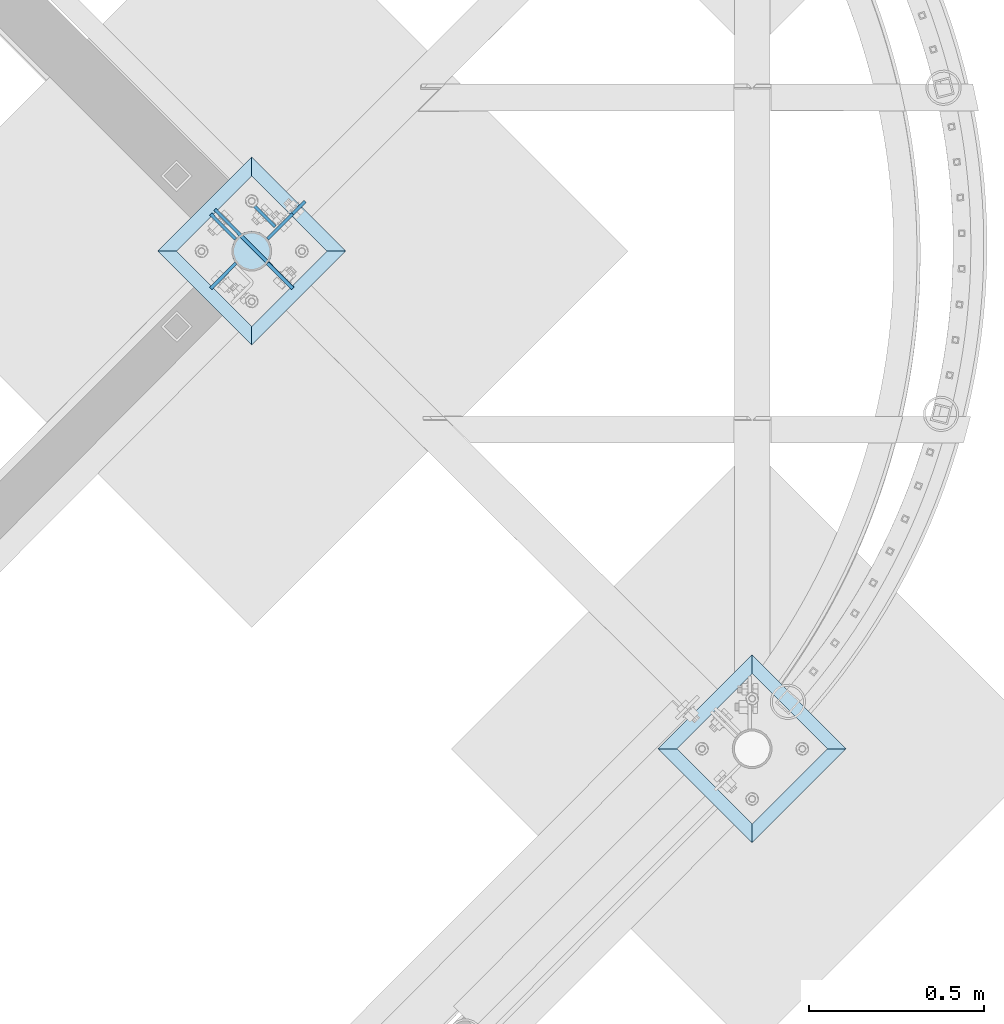
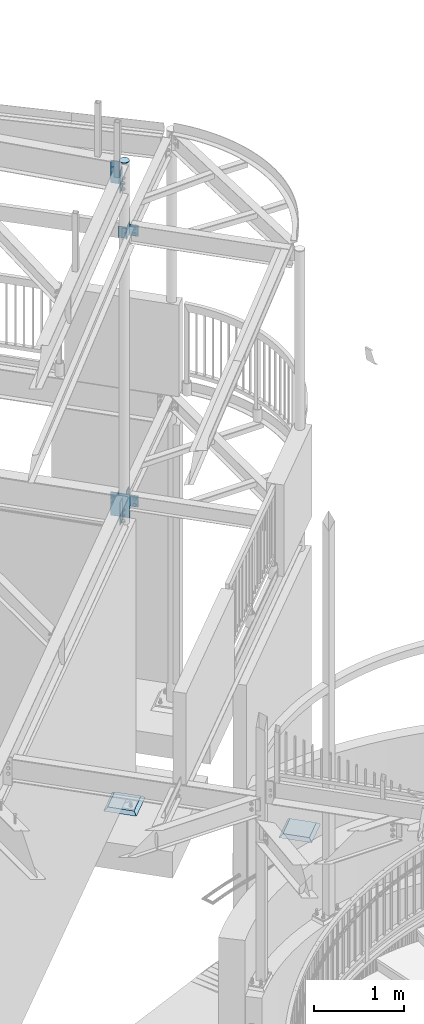
# One storey, part 921 of 975: 11 plates.
"""IFC2X3 building model written with IfcOpenShell, lengths in millimetres."""

import ifcopenshell
import ifcopenshell.guid

model = None  # the IFC model being written
_history = None  # IfcOwnerHistory: only IFC2X3 demands one
_inside = {}  # id of a spatial element -> (the spatial element, [elements in it])
_under = {}  # id of a project, library or spatial element -> (it, [spatial elements below it])
_declared = {}  # id of a project -> (the project, [libraries it declares])
_typed = {}  # id of a type object -> (the type object, [elements of that type])
_made_of = {}  # id of a material, layer set ... -> (it, [elements and type objects made of it])


def new_model(schema):
    """Start an empty IFC model of exactly this schema.

    Asked for "IFC4X3", IfcOpenShell would pick the latest addendum, in which some entities
    have other attributes; the version numbers below select the first issue.
    IFC2X3 requires an IfcOwnerHistory on every rooted entity: one is made here for all.
    """
    global model, _history
    if schema == "IFC4X3":
        model = ifcopenshell.file(schema_version=(4, 3, 0, 0))
    else:
        model = ifcopenshell.file(schema=schema)
    _inside.clear()
    _under.clear()
    _declared.clear()
    _typed.clear()
    _made_of.clear()
    _history = None
    if model.schema == "IFC2X3":
        org = make("IfcOrganization", Name="unknown")
        user = make(
            "IfcPersonAndOrganization",
            ThePerson=make("IfcPerson", FamilyName="unknown"),
            TheOrganization=org,
        )
        app = make(
            "IfcApplication",
            ApplicationDeveloper=org,
            Version="unknown",
            ApplicationFullName="unknown",
            ApplicationIdentifier="unknown",
        )
        _history = make(
            "IfcOwnerHistory",
            OwningUser=user,
            OwningApplication=app,
            ChangeAction="ADDED",
            CreationDate=0,
        )
    return model


def make(cls, **values):
    """One entity of the class cls with the attributes given. An attribute that is None is left unset."""
    return model.create_entity(
        cls, **{name: value for name, value in values.items() if value is not None}
    )


def rooted(cls, **values):
    """An entity with a GlobalId (a new one), such as an element, a storey or a relation."""
    return make(cls, GlobalId=ifcopenshell.guid.new(), OwnerHistory=_history, **values)


def si_unit(unit_type, name, prefix=None):
    """IfcSIUnit, for example si_unit("LENGTHUNIT", "METRE", prefix="MILLI")."""
    return make("IfcSIUnit", UnitType=unit_type, Prefix=prefix, Name=name)


def assignment(units):
    """IfcUnitAssignment: the units of a project."""
    return None if units is None else make("IfcUnitAssignment", Units=units)


def point(xyz):
    """IfcCartesianPoint."""
    return None if xyz is None else make("IfcCartesianPoint", Coordinates=xyz)


def direction(xyz):
    """IfcDirection."""
    return None if xyz is None else make("IfcDirection", DirectionRatios=xyz)


def frame(location, z_axis=None, x_axis=None):
    """IfcAxis2Placement3D, a coordinate frame: its origin and axes. An axis left out is left unset."""
    return make(
        "IfcAxis2Placement3D",
        Location=point(location),
        Axis=direction(z_axis),
        RefDirection=direction(x_axis),
    )


def origin_with_axes():
    """The frame at (0, 0, 0) with the z axis (0, 0, 1) and the x axis (1, 0, 0) written out."""
    return frame((0.0, 0.0, 0.0), z_axis=(0.0, 0.0, 1.0), x_axis=(1.0, 0.0, 0.0))


def place(relative_to, where):
    """IfcLocalPlacement: puts the frame where relative to a parent placement (None: the world)."""
    return make(
        "IfcLocalPlacement", PlacementRelTo=relative_to, RelativePlacement=where
    )


def context(
    kind, dimensions, precision=None, world=None, true_north=None, identifier=None
):
    """IfcGeometricRepresentationContext, for example the 3D "Model" context."""
    return make(
        "IfcGeometricRepresentationContext",
        ContextIdentifier=identifier,
        ContextType=kind,
        CoordinateSpaceDimension=dimensions,
        Precision=precision,
        WorldCoordinateSystem=world,
        TrueNorth=true_north,
    )


def subcontext(parent, identifier, kind, view, scale=None):
    """IfcGeometricRepresentationSubContext, for example "Body" below "Model"."""
    return make(
        "IfcGeometricRepresentationSubContext",
        ContextIdentifier=identifier,
        ContextType=kind,
        ParentContext=parent,
        TargetScale=scale,
        TargetView=view,
    )


def project(units=None, contexts=None):
    """IfcProject with its units and contexts."""
    return rooted(
        "IfcProject",
        Name="project",
        RepresentationContexts=contexts,
        UnitsInContext=assignment(units),
    )


def spatial(cls, under=None, at=None, **own):
    """A site, building, storey or space (cls), placed at a placement, below another one or the project."""
    s = rooted(cls, ObjectPlacement=at, **own)
    if under is not None:
        _under.setdefault(under.id(), (under, []))[1].append(s)
    return s


def faces_of(points, faces, orient=None, outer=None):
    """IfcFace entities. A face is a list of loops; a loop is a list of indices into points, from 0.

    orient and outer hold one flag for each loop. By default every Orientation is true, the
    first loop of a face is its IfcFaceOuterBound and the others are IfcFaceBound.
    """
    made = []
    for i, loops in enumerate(faces):
        bounds = []
        for j, loop in enumerate(loops):
            is_outer = j == 0 if outer is None else outer[i][j]
            bounds.append(
                make(
                    "IfcFaceOuterBound" if is_outer else "IfcFaceBound",
                    Bound=make("IfcPolyLoop", Polygon=[points[k] for k in loop]),
                    Orientation=True if orient is None else orient[i][j],
                )
            )
        made.append(make("IfcFace", Bounds=bounds))
    return made


def faceted_brep(points, faces, orient=None, outer=None, voids=None):
    """IfcFacetedBrep: a solid bounded by flat faces; with voids (closed shells), ...WithVoids."""
    shared = [point(p) for p in points]
    hull = make("IfcClosedShell", CfsFaces=faces_of(shared, faces, orient, outer))
    if voids is None:
        return make("IfcFacetedBrep", Outer=hull)
    return make(
        "IfcFacetedBrepWithVoids",
        Outer=hull,
        Voids=[
            make(cls, CfsFaces=faces_of(shared, fs, o, b)) for cls, fs, o, b in voids
        ],
    )


def shape(context_of_items, identifier, shape_type, items):
    """IfcShapeRepresentation: the items that make up one representation, for example the "Body"."""
    return make(
        "IfcShapeRepresentation",
        ContextOfItems=context_of_items,
        RepresentationIdentifier=identifier,
        RepresentationType=shape_type,
        Items=items,
    )


def material(Name=None, Category=None):
    """IfcMaterial."""
    return make("IfcMaterial", Name=Name, Category=Category)


def made_of(thing, what):
    """Note that an element or type object is made of a material, layer set ...; save() writes the relation."""
    if what is not None:
        _made_of.setdefault(what.id(), (what, []))[1].append(thing)
    return thing


def type_object(cls, material=None, **own):
    """A type object (cls), such as IfcWallType, which elements share."""
    return made_of(rooted(cls, **own), material)


def element(
    cls,
    number,
    at=None,
    inside=None,
    cuts=None,
    type_object=None,
    material=None,
    context=None,
    identifier="Body",
    shape_type=None,
    held_by="IfcProductDefinitionShape",
    body=None,
    shapes=None,
    **own,
):
    """One element of the class cls, such as IfcWall. Its Tag is "e" and its number.

    at: its placement. inside: the storey or other place that contains it. cuts: it is an
    opening in that element (IfcRelVoidsElement). A single representation is given by context,
    identifier, shape_type and body (its items); several are given by shapes. held_by: the class
    of the entity that holds the representations. save() writes the other relations.
    """
    e = rooted(cls, Tag="e%d" % number, ObjectPlacement=at, **own)
    if body is not None:
        shapes = [shape(context, identifier, shape_type, body)]
    if shapes is not None:
        e.Representation = make(held_by, Representations=shapes)
    if inside is not None:
        _inside.setdefault(inside.id(), (inside, []))[1].append(e)
    if cuts is not None:
        rooted(
            "IfcRelVoidsElement", RelatingBuildingElement=cuts, RelatedOpeningElement=e
        )
    if type_object is not None:
        _typed.setdefault(type_object.id(), (type_object, []))[1].append(e)
    return made_of(e, material)


def aggregate(whole, parts):
    """IfcRelAggregates: a whole, such as a stair, and the parts it consists of."""
    return rooted("IfcRelAggregates", RelatingObject=whole, RelatedObjects=parts)


def save(model, path):
    """Write the relations noted so far, then the file.

    IfcRelAggregates (storeys below a building ...), IfcRelContainedInSpatialStructure (elements
    in a storey), IfcRelDefinesByType, IfcRelAssociatesMaterial and IfcRelDeclares: one each for
    every whole, place, type object, material and project.
    """
    for whole, parts in _under.values():
        aggregate(whole, parts)
    for where, things in _inside.values():
        rooted(
            "IfcRelContainedInSpatialStructure",
            RelatedElements=things,
            RelatingStructure=where,
        )
    for kind, things in _typed.values():
        rooted("IfcRelDefinesByType", RelatedObjects=things, RelatingType=kind)
    for what, things in _made_of.values():
        rooted("IfcRelAssociatesMaterial", RelatedObjects=things, RelatingMaterial=what)
    for by, libraries in _declared.values():
        rooted("IfcRelDeclares", RelatingContext=by, RelatedDefinitions=libraries)
    model.write(path)


model = new_model("IFC2X3")

# Units and contexts
model_context = context("Model", 3, precision=1e-05, world=origin_with_axes())
body_context = subcontext(model_context, "Body", "Model", "MODEL_VIEW")
ifc_project = project(units=[si_unit("LENGTHUNIT", "METRE", prefix="MILLI"), si_unit("AREAUNIT", "SQUARE_METRE"), si_unit("VOLUMEUNIT", "CUBIC_METRE"), si_unit("MASSUNIT", "GRAM", prefix="KILO"), si_unit("TIMEUNIT", "SECOND"), si_unit("PLANEANGLEUNIT", "RADIAN"), si_unit("SOLIDANGLEUNIT", "STERADIAN"), si_unit("THERMODYNAMICTEMPERATUREUNIT", "DEGREE_CELSIUS"), si_unit("LUMINOUSINTENSITYUNIT", "LUMEN")], contexts=[model_context])

# Site, building, storey
site_placement = place(None, origin_with_axes())
site = spatial("IfcSite", under=ifc_project, at=site_placement, CompositionType="ELEMENT")
building_placement = place(site_placement, origin_with_axes())
building = spatial("IfcBuilding", under=site, at=building_placement, Name="Undefined", CompositionType="ELEMENT")
storey_placement = place(building_placement, origin_with_axes())
storey = spatial("IfcBuildingStorey", under=building, at=storey_placement, Name="Undefined", CompositionType="ELEMENT", Elevation=0.0)

# Plates
ifc_material_1 = material(Name="STEEL/A36")
plate_type_1 = type_object("IfcPlateType", PredefinedType="NOTDEFINED")
for number, where, z_axis, x_axis, name in (
    (1, (34058.6898757685, 11631.937809576, 8417.04274375628), (-0.704876777842618, -0.709329773841623, 9.89945510809774e-09), (0.0, 0.0, -1.0), "PLATE"),
    (2, (34058.600015857, 11700.9897502071, 8436.38583040211), (-0.706980057333141, 0.70723348233326, 0.0), (0.0, 0.0, -1.0), "PLATE"),
):
    element("IfcPlate", number, at=place(storey_placement, frame(where, z_axis=z_axis, x_axis=x_axis)), inside=storey, type_object=plate_type_1, material=ifc_material_1, Name=name, context=body_context, shape_type="Brep", body=[
        faceted_brep([(0.0, -4.76250000000073, 0.0), (3.09228198602796e-11, -4.76250000006621, 101.59999847407), (3.09228198602796e-11, 4.7624999999407, 101.599998474074), (0.0, 4.76250000000073, 0.0), (304.799987792969, -4.76250000006621, 101.59999847407), (304.799987792969, 4.7624999999407, 101.599998474074), (304.799987792969, -4.76249999999982, 0.0), (304.799987792969, 4.76249999999982, 0.0)], [[[0, 1, 2, 3]], [[1, 4, 5, 2]], [[4, 6, 7, 5]], [[6, 0, 3, 7]], [[5, 7, 3, 2]], [[6, 4, 1, 0]]]),
    ])
for number, where, z_axis, x_axis, name in (
    (3, (34149.542759726, 11631.5828184462, 7594.59999999992), (0.709067143694186, -0.705140968695883, 0.0), (0.0, 0.0, -1.0), "PLATE"),
    (4, (34149.4921648451, 11701.5751692706, 3911.6), (0.707890224195014, 0.706322469194583, 0.0), (0.0, 0.0, -1.0), "PLATE"),
):
    element("IfcPlate", number, at=place(storey_placement, frame(where, z_axis=z_axis, x_axis=x_axis)), inside=storey, type_object=plate_type_1, material=ifc_material_1, Name=name, context=body_context, shape_type="Brep", body=[
        faceted_brep([(0.0, -4.76250000000073, 0.0), (0.0, -4.76249999983702, 101.970382690557), (0.0, 4.76250000017899, 101.970382690564), (0.0, 4.76250000000073, 0.0), (152.399993896484, -4.76249999983702, 101.970382690557), (152.399993896484, 4.76250000017899, 101.970382690564), (152.399993896484, -4.76250000000073, 0.0), (152.399993896484, 4.76250000000073, 0.0)], [[[0, 1, 2, 3]], [[1, 4, 5, 2]], [[4, 6, 7, 5]], [[6, 0, 3, 7]], [[5, 7, 3, 2]], [[6, 4, 1, 0]]]),
    ])
plate_1_placement = place(storey_placement, frame((34058.6755413739, 11631.9613130407, 3898.9), z_axis=(-0.705211376647204, -0.708997118645312, 0.0), x_axis=(0.0, 0.0, -1.0)))
element("IfcPlate", 5, at=plate_1_placement, inside=storey, type_object=plate_type_1, material=ifc_material_1, Name="PLATE", context=body_context, shape_type="Brep", body=[
    faceted_brep([(0.0, -4.76250000000073, 0.0), (0.0, -4.76250000004256, 102.063125610362), (0.0, 4.7624999999407, 102.063125610377), (0.0, 4.76250000000073, 0.0), (304.799987792969, -4.76250000004256, 102.063125610362), (304.799987792969, 4.7624999999407, 102.063125610377), (304.799987792969, -4.76249999999982, 0.0), (304.799987792969, 4.76249999999982, 0.0)], [[[0, 1, 2, 3]], [[1, 4, 5, 2]], [[4, 6, 7, 5]], [[6, 0, 3, 7]], [[5, 7, 3, 2]], [[6, 4, 1, 0]]]),
])
plate_type_2 = type_object("IfcPlateType", PredefinedType="NOTDEFINED")
plate_2_placement = place(storey_placement, frame((34149.4901762041, 11701.5784056277, 7493.0), z_axis=(0.707846168211467, 0.706366620211023, 0.0), x_axis=(0.0, 0.0, -1.0)))
element("IfcPlate", 6, at=plate_2_placement, inside=storey, type_object=plate_type_2, material=ifc_material_1, Name="PLATE", context=body_context, shape_type="Brep", body=[
    faceted_brep([(0.0, -4.76250000000073, 0.0), (0.0, -4.76249999995889, 152.774597167747), (0.0, 4.76250000002983, 152.774597167772), (0.0, 4.76250000000073, 0.0), (152.399993896484, -4.76249999995889, 152.774597167747), (152.399993896484, 4.76250000002983, 152.774597167772), (152.399993896484, -4.76250000000073, 0.0), (152.399993896484, 4.76250000000073, 0.0)], [[[0, 1, 2, 3]], [[1, 4, 5, 2]], [[4, 6, 7, 5]], [[6, 0, 3, 7]], [[5, 7, 3, 2]], [[6, 4, 1, 0]]]),
])
plate_type_3 = type_object("IfcPlateType", PredefinedType="NOTDEFINED")
plate_3_placement = place(storey_placement, frame((34171.1218852476, 11736.627046443, 7479.65399706807), z_axis=(-0.706980057333141, 0.70723348233326, 0.0), x_axis=(0.0, 0.0, -1.0)))
element("IfcPlate", 7, at=plate_3_placement, inside=storey, type_object=plate_type_3, material=ifc_material_1, Name="PLATE", context=body_context, shape_type="Brep", body=[
    faceted_brep([(0.0, -4.76250000000073, 0.0), (0.0, -4.76249999999982, 88.9000015258789), (0.0, 4.76249999999982, 88.9000015258789), (0.0, 4.76250000000073, 0.0), (152.399993896484, -4.76249999999982, 88.9000015258789), (152.399993896484, 4.76249999999982, 88.9000015258789), (152.399993896484, -4.76250000000073, 0.0), (152.399993896484, 4.76250000000073, 0.0)], [[[0, 1, 2, 3]], [[1, 4, 5, 2]], [[4, 6, 7, 5]], [[6, 0, 3, 7]], [[5, 7, 3, 2]], [[6, 4, 1, 0]]]),
])
plate_type_4 = type_object("IfcPlateType", PredefinedType="NOTDEFINED")
plate_4_placement = place(storey_placement, frame((34023.4401949106, 11666.5375000001, 8453.43750012522), z_axis=(0.707106781186513, -0.707106781186582, 3.1377567211166e-14), x_axis=(0.707106781186548, 0.707106781186548, 0.0)))
element("IfcPlate", 8, at=plate_4_placement, inside=storey, type_object=plate_type_4, material=ifc_material_1, Name="PLATE", context=body_context, shape_type="Brep", body=[
    faceted_brep([(-1.45519152283669e-10, -4.76250000000073, 57.1500015256606), (4.35028483294354, -4.76250000000073, 79.0203602693728), (4.35028483294354, 4.76250000000073, 79.0203602693728), (-1.45519152283669e-10, 4.76250000000073, 57.1500015256606), (16.7388479019119, -4.76250000000073, 97.5611551495967), (16.7388479019119, 4.76250000000073, 97.5611551495967), (35.2796427821067, -4.76250000000073, 109.949718218613), (35.2796427821067, 4.76250000000073, 109.949718218613), (57.1500015258789, -4.76250000000073, 114.300003051758), (57.1500015258789, 4.76250000000073, 114.300003051758), (79.0203602694728, -4.76250000000073, 109.949718218628), (79.0203602694728, 4.76250000000073, 109.949718218628), (97.5611551496495, -4.76250000000073, 97.5611551496477), (97.5611551496495, 4.76250000000073, 97.5611551496477), (109.949718218627, -4.76250000000073, 79.020360269471), (109.949718218627, 4.76250000000073, 79.020360269471), (114.300003051758, -4.76250000000073, 57.1500015258061), (114.300003051758, 4.76250000000073, 57.1500015258061), (109.949718218621, -4.76250000000073, 35.2796427821959), (109.949718218621, 4.76250000000073, 35.2796427821959), (97.5611551496231, -4.76250000000073, 16.7388479020083), (97.5611551496231, 4.76250000000073, 16.7388479020083), (79.020360269421, -4.76250000000073, 4.3502848330354), (79.020360269421, 4.76250000000073, 4.3502848330354), (57.1500015256597, -4.76250000000073, -7.27595761418343e-11), (57.1500015256597, 4.76250000000073, -7.27595761418343e-11), (35.2796427821222, -4.76250000000073, 4.35028483306451), (35.2796427821222, 4.76250000000073, 4.35028483306451), (16.7388479019883, -4.76250000000073, 16.7388479020083), (16.7388479019883, 4.76250000000073, 16.7388479020083), (4.35028483301994, -4.76250000000073, 35.2796427821268), (4.35028483301994, 4.76250000000073, 35.2796427821268)], [[[0, 1, 2, 3]], [[1, 4, 5, 2]], [[4, 6, 7, 5]], [[6, 8, 9, 7]], [[8, 10, 11, 9]], [[10, 12, 13, 11]], [[12, 14, 15, 13]], [[14, 16, 17, 15]], [[16, 18, 19, 17]], [[18, 20, 21, 19]], [[20, 22, 23, 21]], [[22, 24, 25, 23]], [[24, 26, 27, 25]], [[26, 28, 29, 27]], [[28, 30, 31, 29]], [[30, 0, 3, 31]], [[5, 7, 9, 11, 13, 15, 17, 19, 21, 23, 25, 27, 29, 31, 3, 2]], [[30, 28, 26, 24, 22, 20, 18, 16, 14, 12, 10, 8, 6, 4, 1, 0]]]),
])
plate_type_5 = type_object("IfcPlateType", PredefinedType="NOTDEFINED")
plate_5_placement = place(storey_placement, frame((34071.179113864, 11713.3266625662, 3911.60000000004), z_axis=(0.0, 0.0, -1.0), x_axis=(0.705007777009209, -0.709199573009272, 0.0)))
element("IfcPlate", 9, at=plate_5_placement, inside=storey, type_object=plate_type_5, material=ifc_material_1, Name="PLATE", context=body_context, shape_type="Brep", body=[
    faceted_brep([(0.0, -4.76250000000073, 0.0), (-102.469268798992, -4.7624999999025, 0.0), (-102.469268798985, 4.76250000008804, 0.0), (0.0, 4.76250000000073, 0.0), (-102.469268798992, -4.7624999999025, 317.5), (-102.469268798985, 4.76250000008804, 317.5), (119.39334106463, -4.76250000009168, 317.5), (119.393341064639, 4.76249999989886, 317.5), (119.39334106463, -4.76250000009168, 158.749993801117), (119.393341064639, 4.76249999989886, 158.749993801117), (119.876706025925, -4.76250000009532, 156.319954042094), (119.876706025934, 4.7624999999025, 156.319954042094), (121.253212976169, -4.76250000009895, 154.259865808017), (121.253212976175, 4.76249999989886, 154.259865808017), (123.313301210246, -4.76250000009168, 152.883358857778), (123.313301210257, 4.76249999989523, 152.883358857778), (125.743340969269, -4.76250000009168, 152.399993896484), (125.74334096928, 4.76249999989523, 152.399993896484), (215.39898681673, -4.76250000017171, 152.399993896484), (215.398986816743, 4.76249999981519, 152.399993896484), (215.39898681673, -4.76250000017171, 0.0), (215.398986816743, 4.76249999981519, 0.0)], [[[0, 1, 2, 3]], [[1, 4, 5, 2]], [[4, 6, 7, 5]], [[6, 8, 9, 7]], [[8, 10, 11, 9]], [[10, 12, 13, 11]], [[12, 14, 15, 13]], [[14, 16, 17, 15]], [[16, 18, 19, 17]], [[18, 20, 21, 19]], [[20, 0, 3, 21]], [[5, 7, 9, 11, 13, 15, 17, 19, 21, 3, 2]], [[20, 18, 16, 14, 12, 10, 8, 6, 4, 1, 0]]]),
])
ifc_material_2 = material(Name="CONCRETE/GROUT")
plate_type_6 = type_object("IfcPlateType", PredefinedType="NOTDEFINED")
for number, where, z_axis, x_axis, name in (
    (10, (35807.1826836313, 10240.9625000001, -285.749999999999), (-0.707106781186548, -0.707106781186548, 0.0), (-0.707106781186601, 0.707106781186494, 2.36468622460961e-14), "GROUT"),
    (11, (34373.6701836314, 11666.5375000001, -285.749999999999), (-0.707106781186548, -0.707106781186548, 0.0), (-0.707106781186601, 0.707106781186494, 2.36468622460961e-14), "GROUT"),
):
    element("IfcPlate", number, at=place(storey_placement, frame(where, z_axis=z_axis, x_axis=x_axis)), inside=storey, type_object=plate_type_6, material=ifc_material_2, Name=name, context=body_context, shape_type="Brep", body=[
        faceted_brep([(38.1000000096292, -19.05, 342.899999985777), (0.0, 19.05, 381.0), (2.63382389675826e-07, 19.0500000000138, 0.0), (38.1000000092372, -19.05, 38.1000000116328), (342.899999988684, -19.05, 38.1000000120257), (381.0, 19.05, 0.0), (381.0, 19.05, 381.0), (342.899999989076, -19.05, 342.89999998617)], [[[0, 1, 2, 3]], [[4, 5, 6, 7]], [[4, 7, 0, 3]], [[5, 4, 3, 2]], [[6, 5, 2, 1]], [[7, 6, 1, 0]]]),
    ])

save(model, "model.ifc")
